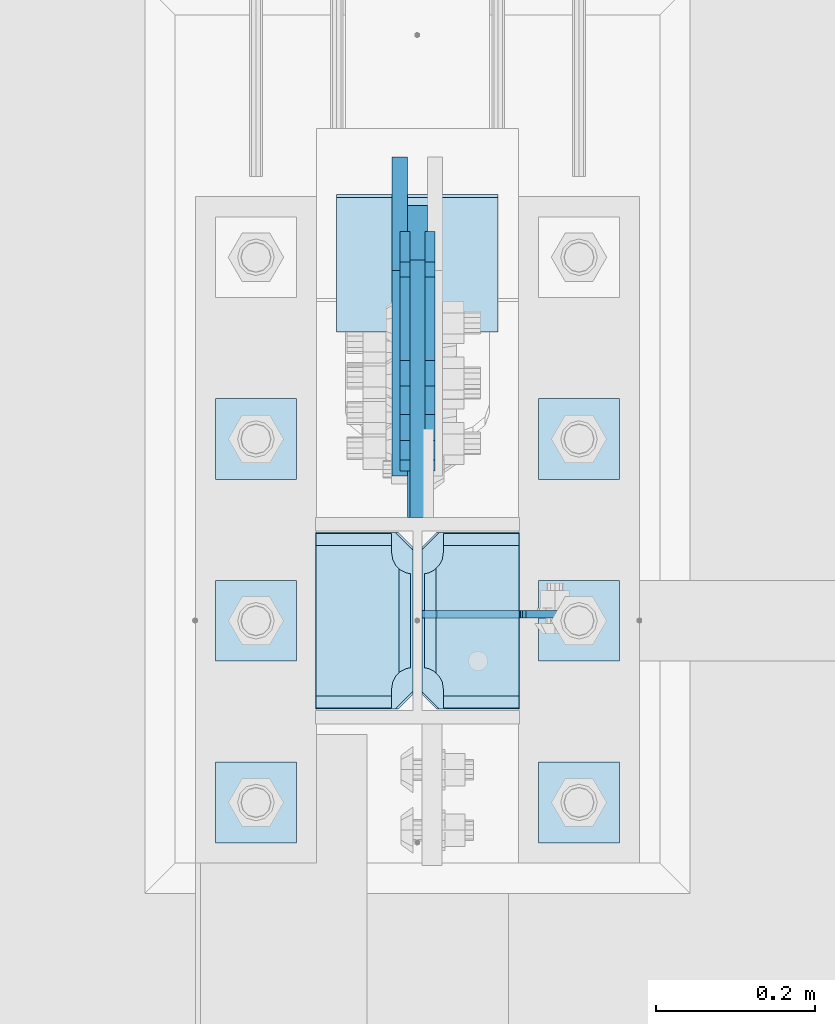
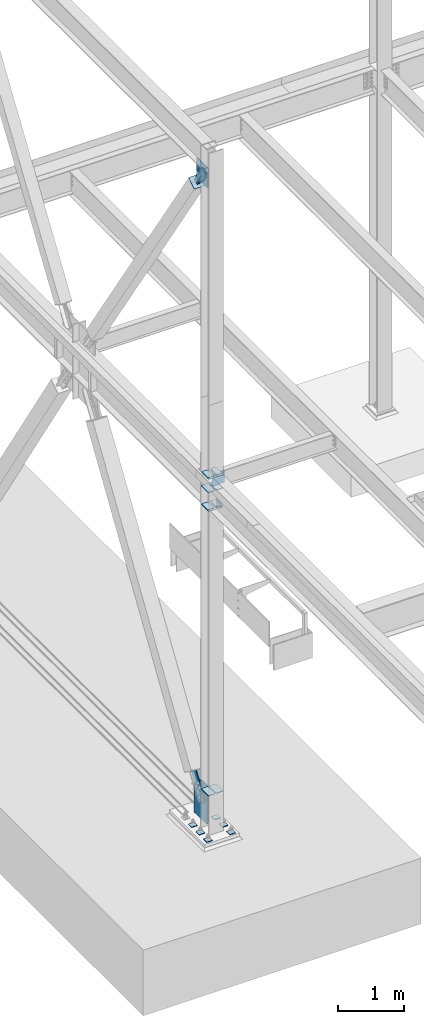
# One storey, part 3330 of 3843: 21 plates, 7 elements without a shape of their own.
"""IFC2X3 building model written with IfcOpenShell, lengths in millimetres."""

from ifc_helpers import new_model, si_unit, frame, origin_with_axes, place, context, subcontext, project, spatial, faceted_brep, material, type_object, element, aggregate, save


model = new_model("IFC2X3")

# Units and contexts
model_context = context("Model", 3, precision=1e-05, world=origin_with_axes())
body_context = subcontext(model_context, "Body", "Model", "MODEL_VIEW")
ifc_project = project(units=[si_unit("LENGTHUNIT", "METRE", prefix="MILLI"), si_unit("AREAUNIT", "SQUARE_METRE"), si_unit("VOLUMEUNIT", "CUBIC_METRE"), si_unit("MASSUNIT", "GRAM", prefix="KILO"), si_unit("TIMEUNIT", "SECOND"), si_unit("PLANEANGLEUNIT", "RADIAN"), si_unit("SOLIDANGLEUNIT", "STERADIAN"), si_unit("THERMODYNAMICTEMPERATUREUNIT", "DEGREE_CELSIUS"), si_unit("LUMINOUSINTENSITYUNIT", "LUMEN")], contexts=[model_context])

# Site, building, storey
site_placement = place(None, origin_with_axes())
site = spatial("IfcSite", under=ifc_project, at=site_placement, CompositionType="ELEMENT")
building_placement = place(site_placement, origin_with_axes())
building = spatial("IfcBuilding", under=site, at=building_placement, Name="Undefined", CompositionType="ELEMENT")
storey_placement = place(building_placement, origin_with_axes())
storey = spatial("IfcBuildingStorey", under=building, at=storey_placement, Name="Undefined", CompositionType="ELEMENT", Elevation=0.0)

# Assembly, plates
assembly_1_placement = place(storey_placement, origin_with_axes())
assembly_1 = element("IfcElementAssembly", 1, at=assembly_1_placement, inside=storey, Name="COLUMN", AssemblyPlace="NOTDEFINED", PredefinedType="RIGID_FRAME")
ifc_material_1 = material(Name="STEEL/A572-50")
plate_type_1 = type_object("IfcPlateType", PredefinedType="NOTDEFINED")
plate_1_placement = place(assembly_1_placement, frame((-128.5875, 96370.775, 30540.5659367631), z_axis=(0.0, 1.0, 0.0), x_axis=(1.0, 0.0, 0.0)))
plate_1 = element("IfcPlate", 2, at=plate_1_placement, type_object=plate_type_1, material=ifc_material_1, Name="STIFFENER", context=body_context, shape_type="Brep", body=[
    faceted_brep([(0.0, -6.3499999046162, 0.0), (0.0, -6.34999999999854, 222.25), (0.0, 6.34999999999854, 222.25), (7.27595761418343e-12, 6.3499999046162, 0.0), (103.981250762939, -6.34999999999854, 222.25), (103.981250762939, 6.34999999999854, 222.25), (123.03125, -6.34999999999854, 203.200000762939), (123.03125, 6.34999999999854, 203.200000762939), (123.03125, -6.34999999999854, 19.0499992370605), (123.03125, 6.34999999999854, 19.0499992370605), (103.981250762939, -6.34999999999854, 0.0), (103.981250762939, 6.34999999999854, 0.0)], [[[0, 1, 2, 3]], [[1, 4, 5, 2]], [[4, 6, 7, 5]], [[6, 8, 9, 7]], [[8, 10, 11, 9]], [[10, 0, 3, 11]], [[5, 7, 9, 11, 3, 2]], [[10, 8, 6, 4, 1, 0]]]),
])
plate_2_placement = place(assembly_1_placement, frame((5.55625, 96370.775, 30540.5659367631), z_axis=(0.0, 1.0, 0.0), x_axis=(1.0, 0.0, 0.0)))
plate_2 = element("IfcPlate", 3, at=plate_2_placement, type_object=plate_type_1, material=ifc_material_1, Name="STIFFENER", context=body_context, shape_type="Brep", body=[
    faceted_brep([(0.0, -6.34999999999854, 19.0499992370605), (0.0, -6.34999999999854, 203.200000762939), (0.0, 6.34999999999854, 203.200000762939), (0.0, 6.34999999999854, 19.0499992370605), (19.0499992370605, -6.34999999999854, 222.25), (19.0499992370605, 6.34999999999854, 222.25), (123.03125, -6.34999999999854, 222.25), (123.03125, 6.34999999999854, 222.25), (123.03125, -6.34999999999854, 0.0), (123.03125, 6.34999999999854, 0.0), (19.0499992370605, -6.34999999999854, 0.0), (19.0499992370605, 6.34999999999854, 0.0)], [[[0, 1, 2, 3]], [[1, 4, 5, 2]], [[4, 6, 7, 5]], [[6, 8, 9, 7]], [[8, 10, 11, 9]], [[10, 0, 3, 11]], [[5, 7, 9, 11, 3, 2]], [[10, 8, 6, 4, 1, 0]]]),
])
plate_type_2 = type_object("IfcPlateType", PredefinedType="NOTDEFINED")
plate_3_placement = place(assembly_1_placement, frame((-5.55625, 96370.775, 36164.8375), z_axis=(0.0, 1.0, 0.0), x_axis=(-1.0, 0.0, 0.0)))
plate_3 = element("IfcPlate", 4, at=plate_3_placement, type_object=plate_type_2, material=ifc_material_1, Name="PLATE", context=body_context, shape_type="Brep", body=[
    faceted_brep([(0.0, -4.76249999999709, 22.2250003814697), (1.77635683940025e-15, -4.76249999999709, 200.02499961853), (1.77635683940025e-15, 4.76249999999709, 200.02499961853), (0.0, 4.76249999999709, 22.2250003814697), (22.2250003814697, -4.76249999999709, 222.25), (22.2250003814697, 4.76249999999709, 222.25), (120.650001525879, -4.76249999999709, 222.25), (120.650001525879, 4.76249999999709, 222.25), (120.650001525879, -4.76249999999709, 0.0), (120.650001525879, 4.76249999999709, 0.0), (22.2250003814697, -4.76249999999709, 0.0), (22.2250003814697, 4.76249999999709, 0.0)], [[[0, 1, 2, 3]], [[1, 4, 5, 2]], [[4, 6, 7, 5]], [[6, 8, 9, 7]], [[8, 10, 11, 9]], [[10, 0, 3, 11]], [[5, 7, 9, 11, 3, 2]], [[10, 8, 6, 4, 1, 0]]]),
])
plate_4_placement = place(assembly_1_placement, frame((126.20625, 96370.775, 36164.8375), z_axis=(0.0, 1.0, 0.0), x_axis=(-1.0, 0.0, 0.0)))
plate_4 = element("IfcPlate", 5, at=plate_4_placement, type_object=plate_type_2, material=ifc_material_1, Name="PLATE", context=body_context, shape_type="Brep", body=[
    faceted_brep([(0.0, -4.76249999999709, 0.0), (7.105427357601e-14, -4.76249999999709, 222.25), (7.105427357601e-14, 4.76249999999709, 222.25), (0.0, 4.76249999999709, 0.0), (98.4249996185303, -4.76249999999709, 222.25), (98.4249996185303, 4.76249999999709, 222.25), (120.65, -4.76249999999709, 200.02499961853), (120.65, 4.76249999999709, 200.02499961853), (120.65, -4.76249999999709, 22.2250003814697), (120.65, 4.76249999999709, 22.2250003814697), (98.4249996185303, -4.76249999999709, 0.0), (98.4249996185303, 4.76249999999709, 0.0)], [[[0, 1, 2, 3]], [[1, 4, 5, 2]], [[4, 6, 7, 5]], [[6, 8, 9, 7]], [[8, 10, 11, 9]], [[10, 0, 3, 11]], [[5, 7, 9, 11, 3, 2]], [[10, 8, 6, 4, 1, 0]]]),
])
plate_type_3 = type_object("IfcPlateType", PredefinedType="NOTDEFINED")
plate_5_placement = place(assembly_1_placement, frame((-5.55625, 96369.1875, 35826.7), z_axis=(0.0, 1.0, 0.0), x_axis=(-1.0, 0.0, 0.0)))
plate_5 = element("IfcPlate", 6, at=plate_5_placement, type_object=plate_type_3, material=ifc_material_1, Name="PLATE", context=body_context, shape_type="Brep", body=[
    faceted_brep([(15.8628540477987, 9.2764413265686, 176.60415524448), (17.8394465694582, 12.6999999999971, 178.580747766144), (17.8394465694582, 12.6999999999971, 46.8442522338592), (15.8628540477985, 9.2764413265686, 48.8208447555226), (8.33959589993262, -3.75422402399272, 52.6541362449789), (3.17474995228986, -12.6999999999971, 53.4721674797547), (3.17474995228986, -12.6999999999971, 171.952832520248), (8.33959589993288, -3.75422402399272, 172.770863755024), (122.237500000003, 12.6999999999971, 17.8391965695046), (122.237500000003, -12.6999999999971, 3.17449995232892), (26.9874992370605, -12.6999999999971, 3.17449995232892), (26.9874992370605, 12.6999999999971, 17.8391965695046), (26.9874992370605, 12.6999999999971, 207.584803430516), (26.9874992370605, -12.6999999999971, 222.249500047692), (122.237500000003, -12.6999999999971, 222.249500047692), (122.237500000003, 12.6999999999971, 207.584803430516), (8.33959589993174, -12.6999999999971, 172.770863755024), (15.8628540477948, -12.6999999999971, 176.60415524448), (21.833345518462, -12.6999999999971, 182.574646715148), (21.833345518462, 12.6999999999971, 182.574646715148), (25.6666370079183, -12.6999999999971, 190.097904863011), (25.6666370079183, 12.6999999999971, 190.097904863011), (26.9874992370605, -12.6999999999971, 198.437500762942), (26.9874992370605, 12.6999999999971, 198.437500762942), (26.9874992370605, -12.6999999999971, 26.9874992370605), (26.9874992370605, 12.6999999999971, 26.9874992370605), (25.6666370079183, -12.6999999999971, 35.3270951369923), (25.6666370079183, 12.6999999999971, 35.3270951369923), (21.833345518462, -12.6999999999971, 42.8503532848626), (21.833345518462, 12.6999999999971, 42.8503532848626), (15.8628540477948, -12.6999999999971, 48.8208447555226), (8.33959589993174, -12.6999999999971, 52.6541362449789)], [[[0, 1, 2, 3, 4, 5, 6, 7]], [[8, 9, 10, 11]], [[12, 13, 14, 15]], [[16, 7, 6]], [[16, 17, 0, 7]], [[17, 18, 19, 1, 0]], [[18, 20, 21, 19]], [[20, 22, 23, 21]], [[23, 22, 13, 12]], [[15, 14, 9, 8]], [[24, 25, 11, 10]], [[24, 26, 27, 25]], [[26, 28, 29, 27]], [[29, 28, 30, 3, 2]], [[30, 31, 4, 3]], [[31, 5, 4]], [[19, 21, 23, 12, 15, 8, 11, 25, 27, 29, 2, 1]], [[31, 30, 28, 26, 24, 10, 9, 14, 13, 22, 20, 18, 17, 16, 6, 5]]]),
])
plate_6_placement = place(assembly_1_placement, frame((-5.55625, 96369.1875, 36423.6), z_axis=(0.0, 1.0, 0.0), x_axis=(-1.0, 0.0, 0.0)))
plate_6 = element("IfcPlate", 7, at=plate_6_placement, type_object=plate_type_3, material=ifc_material_1, Name="PLATE", context=body_context, shape_type="Brep", body=[
    faceted_brep([(15.8628540477987, 9.2764413265686, 176.60415524448), (17.8394465694582, 12.6999999999971, 178.580747766144), (17.8394465694582, 12.6999999999971, 46.8442522338592), (15.8628540477985, 9.2764413265686, 48.8208447555226), (8.33959589993262, -3.75422402399272, 52.6541362449789), (3.17474995228986, -12.6999999999971, 53.4721674797547), (3.17474995228986, -12.6999999999971, 171.952832520248), (8.33959589993288, -3.75422402399272, 172.770863755024), (26.9874992370605, 12.6999999999971, 207.584803430516), (26.9874992370605, -12.6999999999971, 222.249500047692), (122.237500000003, -12.6999999999971, 222.249500047692), (122.237500000003, 12.6999999999971, 207.584803430516), (122.237500000003, 12.6999999999971, 17.8391965695046), (122.237500000003, -12.6999999999971, 3.17449995232892), (26.9874992370605, -12.6999999999971, 3.17449995232892), (26.9874992370605, 12.6999999999971, 17.8391965695046), (8.33959589993174, -12.6999999999971, 172.770863755024), (15.8628540477948, -12.6999999999971, 176.60415524448), (21.833345518462, -12.6999999999971, 182.574646715148), (21.833345518462, 12.6999999999971, 182.574646715148), (25.6666370079183, -12.6999999999971, 190.097904863011), (25.6666370079183, 12.6999999999971, 190.097904863011), (26.9874992370605, -12.6999999999971, 198.437500762942), (26.9874992370605, 12.6999999999971, 198.437500762942), (26.9874992370605, -12.6999999999971, 26.9874992370605), (26.9874992370605, 12.6999999999971, 26.9874992370605), (25.6666370079183, -12.6999999999971, 35.3270951369923), (25.6666370079183, 12.6999999999971, 35.3270951369923), (21.833345518462, -12.6999999999971, 42.8503532848626), (21.833345518462, 12.6999999999971, 42.8503532848626), (15.8628540477948, -12.6999999999971, 48.8208447555226), (8.33959589993174, -12.6999999999971, 52.6541362449789)], [[[0, 1, 2, 3, 4, 5, 6, 7]], [[8, 9, 10, 11]], [[12, 13, 14, 15]], [[16, 7, 6]], [[16, 17, 0, 7]], [[17, 18, 19, 1, 0]], [[18, 20, 21, 19]], [[20, 22, 23, 21]], [[23, 22, 9, 8]], [[11, 10, 13, 12]], [[24, 25, 15, 14]], [[24, 26, 27, 25]], [[26, 28, 29, 27]], [[29, 28, 30, 3, 2]], [[30, 31, 4, 3]], [[31, 5, 4]], [[19, 21, 23, 8, 11, 12, 15, 25, 27, 29, 2, 1]], [[31, 30, 28, 26, 24, 14, 13, 10, 9, 22, 20, 18, 17, 16, 6, 5]]]),
])
plate_7_placement = place(assembly_1_placement, frame((127.79375, 96369.1875, 35826.7), z_axis=(0.0, 1.0, 0.0), x_axis=(-1.0, 0.0, 0.0)))
plate_7 = element("IfcPlate", 8, at=plate_7_placement, type_object=plate_type_3, material=ifc_material_1, Name="PLATE", context=body_context, shape_type="Brep", body=[
    faceted_brep([(106.374645952202, 9.2764413265686, 48.8208447555226), (104.398053430486, 12.6999999999971, 46.8442522338009), (104.398053430486, 12.6999999999971, 178.580747766202), (106.374645952201, 9.2764413265686, 176.60415524448), (113.897904100067, -3.75422402399272, 172.770863755024), (119.062750047655, -12.6999999999971, 171.952832520255), (119.062750047655, -12.6999999999971, 53.4721674797474), (113.897904100067, -3.75422402399272, 52.6541362449789), (0.0, 12.6999999999971, 207.584803430516), (0.0, -12.6999999999971, 222.249500047692), (95.2500007629424, -12.6999999999971, 222.249500047692), (95.2500007629424, 12.6999999999971, 207.584803430516), (95.2500007629424, 12.6999999999971, 17.8391965694973), (95.2500007629424, -12.6999999999971, 3.17449995232164), (0.0, -12.6999999999971, 3.17449995232164), (0.0, 12.6999999999971, 17.8391965694973), (95.2500007629424, -12.6999999999971, 198.437500762942), (95.2500007629424, 12.6999999999971, 198.437500762942), (96.5708629920846, -12.6999999999971, 190.097904863011), (96.5708629920846, 12.6999999999971, 190.097904863011), (100.404154481541, -12.6999999999971, 182.574646715148), (100.404154481541, 12.6999999999971, 182.574646715148), (106.374645952208, -12.6999999999971, 176.60415524448), (113.897904100071, -12.6999999999971, 172.770863755024), (113.897904100071, -12.6999999999971, 52.6541362449789), (106.374645952208, -12.6999999999971, 48.8208447555226), (100.404154481541, -12.6999999999971, 42.8503532848626), (100.404154481541, 12.6999999999971, 42.8503532848626), (96.5708629920846, -12.6999999999971, 35.3270951369923), (96.5708629920846, 12.6999999999971, 35.3270951369923), (95.2500007629424, -12.6999999999971, 26.9874992370605), (95.2500007629424, 12.6999999999971, 26.9874992370605)], [[[0, 1, 2, 3, 4, 5, 6, 7]], [[8, 9, 10, 11]], [[12, 13, 14, 15]], [[15, 14, 9, 8]], [[16, 17, 11, 10]], [[16, 18, 19, 17]], [[18, 20, 21, 19]], [[21, 20, 22, 3, 2]], [[22, 23, 4, 3]], [[23, 5, 4]], [[24, 7, 6]], [[24, 25, 0, 7]], [[25, 26, 27, 1, 0]], [[26, 28, 29, 27]], [[28, 30, 31, 29]], [[31, 30, 13, 12]], [[27, 29, 31, 12, 15, 8, 11, 17, 19, 21, 2, 1]], [[13, 30, 28, 26, 25, 24, 6, 5, 23, 22, 20, 18, 16, 10, 9, 14]]]),
])
plate_8_placement = place(assembly_1_placement, frame((127.79375, 96369.1875, 36423.6), z_axis=(0.0, 1.0, 0.0), x_axis=(-1.0, 0.0, 0.0)))
plate_8 = element("IfcPlate", 9, at=plate_8_placement, type_object=plate_type_3, material=ifc_material_1, Name="PLATE", context=body_context, shape_type="Brep", body=[
    faceted_brep([(106.374645952202, 9.2764413265686, 48.8208447555226), (104.398053430486, 12.6999999999971, 46.8442522338009), (104.398053430486, 12.6999999999971, 178.580747766202), (106.374645952201, 9.2764413265686, 176.60415524448), (113.897904100067, -3.75422402399272, 172.770863755024), (119.062750047655, -12.6999999999971, 171.952832520255), (119.062750047655, -12.6999999999971, 53.4721674797474), (113.897904100067, -3.75422402399272, 52.6541362449789), (0.0, 12.6999999999971, 207.584803430516), (0.0, -12.6999999999971, 222.249500047692), (95.2500007629424, -12.6999999999971, 222.249500047692), (95.2500007629424, 12.6999999999971, 207.584803430516), (95.2500007629424, 12.6999999999971, 17.8391965694973), (95.2500007629424, -12.6999999999971, 3.17449995232164), (0.0, -12.6999999999971, 3.17449995232164), (0.0, 12.6999999999971, 17.8391965694973), (95.2500007629424, -12.6999999999971, 198.437500762942), (95.2500007629424, 12.6999999999971, 198.437500762942), (96.5708629920846, -12.6999999999971, 190.097904863011), (96.5708629920846, 12.6999999999971, 190.097904863011), (100.404154481541, -12.6999999999971, 182.574646715148), (100.404154481541, 12.6999999999971, 182.574646715148), (106.374645952208, -12.6999999999971, 176.60415524448), (113.897904100071, -12.6999999999971, 172.770863755024), (113.897904100071, -12.6999999999971, 52.6541362449789), (106.374645952208, -12.6999999999971, 48.8208447555226), (100.404154481541, -12.6999999999971, 42.8503532848626), (100.404154481541, 12.6999999999971, 42.8503532848626), (96.5708629920846, -12.6999999999971, 35.3270951369923), (96.5708629920846, 12.6999999999971, 35.3270951369923), (95.2500007629424, -12.6999999999971, 26.9874992370605), (95.2500007629424, 12.6999999999971, 26.9874992370605)], [[[0, 1, 2, 3, 4, 5, 6, 7]], [[8, 9, 10, 11]], [[12, 13, 14, 15]], [[15, 14, 9, 8]], [[16, 17, 11, 10]], [[16, 18, 19, 17]], [[18, 20, 21, 19]], [[21, 20, 22, 3, 2]], [[22, 23, 4, 3]], [[23, 5, 4]], [[24, 7, 6]], [[24, 25, 0, 7]], [[25, 26, 27, 1, 0]], [[26, 28, 29, 27]], [[28, 30, 31, 29]], [[31, 30, 13, 12]], [[27, 29, 31, 12, 15, 8, 11, 17, 19, 21, 2, 1]], [[13, 30, 28, 26, 25, 24, 6, 5, 23, 22, 20, 18, 16, 10, 9, 14]]]),
])

# Assembly, plate
assembly_2_placement = place(storey_placement, origin_with_axes())
assembly_2 = element("IfcElementAssembly", 10, at=assembly_2_placement, inside=storey, AssemblyPlace="NOTDEFINED", PredefinedType="RIGID_FRAME")
ifc_material_2 = material(Name="STEEL/A36")
plate_type_4 = type_object("IfcPlateType", PredefinedType="NOTDEFINED")
plate_9_placement = place(assembly_2_placement, frame((-15.875, 96933.0535545789, 41635.915781687), z_axis=(0.0, -0.83424452268884, -0.551394664794346), x_axis=(0.0, 0.551394664794348, -0.834244522688839)))
plate_9 = element("IfcPlate", 11, at=plate_9_placement, type_object=plate_type_4, material=ifc_material_2, context=body_context, shape_type="Brep", body=[
    faceted_brep([(0.0, -6.3499999046162, 0.0), (-101.599999999482, -6.35000000000582, -44.6881937832222), (-101.599999999482, 6.35000000000582, -44.6881937832222), (7.27595761418343e-12, 6.3499999046162, 0.0), (-246.684985846376, -6.35000000000582, -44.6881937832586), (-246.684985846376, 6.35000000000582, -44.6881937832586), (-281.313054100305, -6.35000000000582, -37.8002427490646), (-281.313054100305, 6.35000000000582, -37.8002427490646), (-310.669312866783, -6.35000000000582, -18.18501775197), (-310.669312866783, 6.35000000000582, -18.18501775197), (-330.284537863758, -6.35000000000582, 11.1712410146756), (-330.284537863758, 6.35000000000582, 11.1712410146756), (-337.172488897893, -6.35000000000582, 45.7993031645856), (-337.172488897893, 6.35000000000582, 45.7993031645856), (-330.284537863699, -6.35000000000582, 80.4273714186893), (-330.284537863699, 6.35000000000582, 80.4273714186893), (-310.669312866681, -6.35000000000582, 109.783630185331), (-310.669312866681, 6.35000000000582, 109.783630185331), (-281.313054100174, -6.35000000000582, 129.39885518244), (-281.313054100174, 6.35000000000582, 129.39885518244), (-246.684988898312, -6.35000000000582, 136.286806216667), (-246.684988898312, 6.35000000000582, 136.286806216667), (-101.599999999322, -6.35000000000582, 136.286806216689), (-101.599999999322, 6.35000000000582, 136.286806216689), (2.18278728425503e-10, -6.35000000000582, 91.5986124321353), (2.18278728425503e-10, 6.35000000000582, 91.5986124321353), (69.8499999987471, -6.35000000000582, 91.598612432037), (69.8499999987471, 6.35000000000582, 91.598612432037), (69.8499999985434, -6.35000000000582, -8.73114913702011e-11), (69.8499999985434, 6.35000000000582, -8.73114913702011e-11)], [[[0, 1, 2, 3]], [[1, 4, 5, 2]], [[4, 6, 7, 5]], [[6, 8, 9, 7]], [[8, 10, 11, 9]], [[10, 12, 13, 11]], [[12, 14, 15, 13]], [[14, 16, 17, 15]], [[16, 18, 19, 17]], [[18, 20, 21, 19]], [[20, 22, 23, 21]], [[22, 24, 25, 23]], [[24, 26, 27, 25]], [[26, 28, 29, 27]], [[28, 0, 3, 29]], [[5, 7, 9, 11, 13, 15, 17, 19, 21, 23, 25, 27, 29, 3, 2]], [[28, 26, 24, 22, 20, 18, 16, 14, 12, 10, 8, 6, 4, 1, 0]]]),
])
aggregate(assembly_2, [plate_9])

assembly_3_placement = place(storey_placement, origin_with_axes())
assembly_3 = element("IfcElementAssembly", 12, at=assembly_3_placement, inside=storey, AssemblyPlace="NOTDEFINED", PredefinedType="RIGID_FRAME")
plate_10_placement = place(assembly_3_placement, frame((15.875, 96933.0535545789, 41635.915781687), z_axis=(0.0, -0.83424452268884, -0.551394664794346), x_axis=(0.0, 0.551394664794348, -0.834244522688839)))
plate_10 = element("IfcPlate", 13, at=plate_10_placement, type_object=plate_type_4, material=ifc_material_2, context=body_context, shape_type="Brep", body=[
    faceted_brep([(0.0, -6.3499999046162, 0.0), (-101.599999999482, -6.35000000000582, -44.6881937832222), (-101.599999999482, 6.35000000000582, -44.6881937832222), (7.27595761418343e-12, 6.3499999046162, 0.0), (-246.684985846376, -6.35000000000582, -44.6881937832586), (-246.684985846376, 6.35000000000582, -44.6881937832586), (-281.313054100305, -6.35000000000582, -37.8002427490646), (-281.313054100305, 6.35000000000582, -37.8002427490646), (-310.669312866783, -6.35000000000582, -18.18501775197), (-310.669312866783, 6.35000000000582, -18.18501775197), (-330.284537863758, -6.35000000000582, 11.1712410146756), (-330.284537863758, 6.35000000000582, 11.1712410146756), (-337.172488897893, -6.35000000000582, 45.7993031645856), (-337.172488897893, 6.35000000000582, 45.7993031645856), (-330.284537863699, -6.35000000000582, 80.4273714186893), (-330.284537863699, 6.35000000000582, 80.4273714186893), (-310.669312866681, -6.35000000000582, 109.783630185331), (-310.669312866681, 6.35000000000582, 109.783630185331), (-281.313054100174, -6.35000000000582, 129.39885518244), (-281.313054100174, 6.35000000000582, 129.39885518244), (-246.684988898312, -6.35000000000582, 136.286806216667), (-246.684988898312, 6.35000000000582, 136.286806216667), (-101.599999999322, -6.35000000000582, 136.286806216689), (-101.599999999322, 6.35000000000582, 136.286806216689), (2.18278728425503e-10, -6.35000000000582, 91.5986124321353), (2.18278728425503e-10, 6.35000000000582, 91.5986124321353), (69.8499999987471, -6.35000000000582, 91.598612432037), (69.8499999987471, 6.35000000000582, 91.598612432037), (69.8499999985434, -6.35000000000582, -8.73114913702011e-11), (69.8499999985434, 6.35000000000582, -8.73114913702011e-11)], [[[0, 1, 2, 3]], [[1, 4, 5, 2]], [[4, 6, 7, 5]], [[6, 8, 9, 7]], [[8, 10, 11, 9]], [[10, 12, 13, 11]], [[12, 14, 15, 13]], [[14, 16, 17, 15]], [[16, 18, 19, 17]], [[18, 20, 21, 19]], [[20, 22, 23, 21]], [[22, 24, 25, 23]], [[24, 26, 27, 25]], [[26, 28, 29, 27]], [[28, 0, 3, 29]], [[5, 7, 9, 11, 13, 15, 17, 19, 21, 23, 25, 27, 29, 3, 2]], [[28, 26, 24, 22, 20, 18, 16, 14, 12, 10, 8, 6, 4, 1, 0]]]),
])
aggregate(assembly_3, [plate_10])

assembly_4_placement = place(storey_placement, origin_with_axes())
assembly_4 = element("IfcElementAssembly", 14, at=assembly_4_placement, inside=storey, Name="Plate", AssemblyPlace="NOTDEFINED", PredefinedType="RIGID_FRAME")
plate_type_5 = type_object("IfcPlateType", PredefinedType="NOTDEFINED")
plate_11_placement = place(assembly_4_placement, frame((-101.6, 96846.8507302591, 41499.0173371492), z_axis=(0.0, 0.83424452268884, 0.551394664794346), x_axis=(1.0, 0.0, 0.0)))
plate_11 = element("IfcPlate", 15, at=plate_11_placement, type_object=plate_type_5, material=ifc_material_2, Name="Plate", context=body_context, shape_type="Brep", body=[
    faceted_brep([(0.0, -3.17499999999927, 0.0), (0.0, -3.17500000043947, 203.200000001736), (0.0, 3.1749999995518, 203.200000001743), (0.0, 3.17499999999927, 0.0), (203.200000000012, -3.17500000043947, 203.200000001736), (203.200000000012, 3.1749999995518, 203.200000001743), (203.199996948242, -3.17499999999927, 0.0), (203.199996948242, 3.17499999999927, 0.0)], [[[0, 1, 2, 3]], [[1, 4, 5, 2]], [[4, 6, 7, 5]], [[6, 0, 3, 7]], [[5, 7, 3, 2]], [[6, 4, 1, 0]]]),
])
aggregate(assembly_4, [plate_11])

assembly_5_placement = place(storey_placement, origin_with_axes())
assembly_5 = element("IfcElementAssembly", 16, at=assembly_5_placement, inside=storey, Name="CB", AssemblyPlace="NOTDEFINED", PredefinedType="RIGID_FRAME")
plate_type_6 = type_object("IfcPlateType", PredefinedType="NOTDEFINED")
plate_12_placement = place(assembly_5_placement, frame((0.0, 96935.5025515636, 42002.075), z_axis=(0.0, 0.0, -1.0), x_axis=(0.0, -1.0, 0.0)))
plate_12 = element("IfcPlate", 17, at=plate_12_placement, type_object=plate_type_6, material=ifc_material_1, Name="CB", context=body_context, shape_type="Brep", body=[
    faceted_brep([(0.0, -9.52500000000146, 0.0), (0.0, -9.525, 242.753716677165), (0.0, 9.525, 242.753716677165), (0.0, 9.52500000000146, 0.0), (193.357024246216, -9.525, 370.553215109874), (193.357024246216, 9.525, 370.553215109874), (323.427549285712, -9.525, 370.553215109874), (323.427549285712, 9.525, 370.553215109874), (323.427549285712, -9.525, 0.0), (323.427549285712, 9.525, 0.0)], [[[0, 1, 2, 3]], [[1, 4, 5, 2]], [[4, 6, 7, 5]], [[6, 8, 9, 7]], [[8, 0, 3, 9]], [[5, 7, 9, 3, 2]], [[8, 6, 4, 1, 0]]]),
])
aggregate(assembly_5, [plate_12])

# Assembly, plates
assembly_6_placement = place(storey_placement, origin_with_axes())
assembly_6 = element("IfcElementAssembly", 18, at=assembly_6_placement, inside=storey, Name="TEMPLATE", AssemblyPlace="NOTDEFINED", PredefinedType="RIGID_FRAME")
plate_type_7 = type_object("IfcPlateType", PredefinedType="NOTDEFINED")
plate_13_placement = place(assembly_6_placement, frame((-152.4, 96304.1, 29825.95), z_axis=(-1.0, 0.0, 0.0), x_axis=(0.0, -1.0, 0.0)))
plate_13 = element("IfcPlate", 19, at=plate_13_placement, type_object=plate_type_7, material=ifc_material_1, Name="Washer Plate", context=body_context, shape_type="Brep", body=[
    faceted_brep([(0.0, -6.3499999046162, 0.0), (-1.67347025126219e-10, -6.35000000000582, 101.600000000151), (-1.67347025126219e-10, 6.35000000000582, 101.600000000151), (7.27595761418343e-12, 6.3499999046162, 0.0), (101.599998474121, -6.34999999999854, 101.599998474121), (101.599998474121, 6.34999999999854, 101.599998474121), (101.6, -6.34999999999854, 0.0), (101.6, 6.34999999999854, 0.0)], [[[0, 1, 2, 3]], [[1, 4, 5, 2]], [[4, 6, 7, 5]], [[6, 0, 3, 7]], [[5, 7, 3, 2]], [[6, 4, 1, 0]]]),
])
plate_14_placement = place(assembly_6_placement, frame((254.0, 96304.1, 29825.95), z_axis=(-1.0, 0.0, 0.0), x_axis=(0.0, -1.0, 0.0)))
plate_14 = element("IfcPlate", 20, at=plate_14_placement, type_object=plate_type_7, material=ifc_material_1, Name="Washer Plate", context=body_context, shape_type="Brep", body=[
    faceted_brep([(0.0, -6.3499999046162, 0.0), (-1.67347025126219e-10, -6.35000000000582, 101.600000000151), (-1.67347025126219e-10, 6.35000000000582, 101.600000000151), (7.27595761418343e-12, 6.3499999046162, 0.0), (101.599998474121, -6.34999999999854, 101.599998474121), (101.599998474121, 6.34999999999854, 101.599998474121), (101.6, -6.34999999999854, 0.0), (101.6, 6.34999999999854, 0.0)], [[[0, 1, 2, 3]], [[1, 4, 5, 2]], [[4, 6, 7, 5]], [[6, 0, 3, 7]], [[5, 7, 3, 2]], [[6, 4, 1, 0]]]),
])
plate_15_placement = place(assembly_6_placement, frame((-152.4, 96532.7, 29825.95), z_axis=(-1.0, 0.0, 0.0), x_axis=(0.0, -1.0, 0.0)))
plate_15 = element("IfcPlate", 21, at=plate_15_placement, type_object=plate_type_7, material=ifc_material_1, Name="Washer Plate", context=body_context, shape_type="Brep", body=[
    faceted_brep([(0.0, -6.3499999046162, 0.0), (-1.67347025126219e-10, -6.35000000000582, 101.600000000151), (-1.67347025126219e-10, 6.35000000000582, 101.600000000151), (7.27595761418343e-12, 6.3499999046162, 0.0), (101.599998474121, -6.34999999999854, 101.599998474121), (101.599998474121, 6.34999999999854, 101.599998474121), (101.6, -6.34999999999854, 0.0), (101.6, 6.34999999999854, 0.0)], [[[0, 1, 2, 3]], [[1, 4, 5, 2]], [[4, 6, 7, 5]], [[6, 0, 3, 7]], [[5, 7, 3, 2]], [[6, 4, 1, 0]]]),
])
plate_16_placement = place(assembly_6_placement, frame((254.0, 96532.7, 29825.95), z_axis=(-1.0, 0.0, 0.0), x_axis=(0.0, -1.0, 0.0)))
plate_16 = element("IfcPlate", 22, at=plate_16_placement, type_object=plate_type_7, material=ifc_material_1, Name="Washer Plate", context=body_context, shape_type="Brep", body=[
    faceted_brep([(0.0, -6.3499999046162, 0.0), (-1.67347025126219e-10, -6.35000000000582, 101.600000000151), (-1.67347025126219e-10, 6.35000000000582, 101.600000000151), (7.27595761418343e-12, 6.3499999046162, 0.0), (101.599998474121, -6.34999999999854, 101.599998474121), (101.599998474121, 6.34999999999854, 101.599998474121), (101.6, -6.34999999999854, 0.0), (101.6, 6.34999999999854, 0.0)], [[[0, 1, 2, 3]], [[1, 4, 5, 2]], [[4, 6, 7, 5]], [[6, 0, 3, 7]], [[5, 7, 3, 2]], [[6, 4, 1, 0]]]),
])
plate_17_placement = place(assembly_6_placement, frame((-152.4, 96761.3, 29825.95), z_axis=(-1.0, 0.0, 0.0), x_axis=(0.0, -1.0, 0.0)))
plate_17 = element("IfcPlate", 23, at=plate_17_placement, type_object=plate_type_7, material=ifc_material_1, Name="Washer Plate", context=body_context, shape_type="Brep", body=[
    faceted_brep([(0.0, -6.3499999046162, 0.0), (-1.67347025126219e-10, -6.35000000000582, 101.600000000151), (-1.67347025126219e-10, 6.35000000000582, 101.600000000151), (7.27595761418343e-12, 6.3499999046162, 0.0), (101.599998474121, -6.34999999999854, 101.599998474121), (101.599998474121, 6.34999999999854, 101.599998474121), (101.6, -6.34999999999854, 0.0), (101.6, 6.34999999999854, 0.0)], [[[0, 1, 2, 3]], [[1, 4, 5, 2]], [[4, 6, 7, 5]], [[6, 0, 3, 7]], [[5, 7, 3, 2]], [[6, 4, 1, 0]]]),
])
plate_18_placement = place(assembly_6_placement, frame((254.0, 96761.3, 29825.95), z_axis=(-1.0, 0.0, 0.0), x_axis=(0.0, -1.0, 0.0)))
plate_18 = element("IfcPlate", 24, at=plate_18_placement, type_object=plate_type_7, material=ifc_material_1, Name="Washer Plate", context=body_context, shape_type="Brep", body=[
    faceted_brep([(0.0, -6.3499999046162, 0.0), (-1.67347025126219e-10, -6.35000000000582, 101.600000000151), (-1.67347025126219e-10, 6.35000000000582, 101.600000000151), (7.27595761418343e-12, 6.3499999046162, 0.0), (101.599998474121, -6.34999999999854, 101.599998474121), (101.599998474121, 6.34999999999854, 101.599998474121), (101.6, -6.34999999999854, 0.0), (101.6, 6.34999999999854, 0.0)], [[[0, 1, 2, 3]], [[1, 4, 5, 2]], [[4, 6, 7, 5]], [[6, 0, 3, 7]], [[5, 7, 3, 2]], [[6, 4, 1, 0]]]),
])
aggregate(assembly_6, [plate_13, plate_14, plate_15, plate_16, plate_17, plate_18])

# Assembly, plate
assembly_7_placement = place(storey_placement, origin_with_axes())
assembly_7 = element("IfcElementAssembly", 25, at=assembly_7_placement, inside=storey, AssemblyPlace="NOTDEFINED", PredefinedType="RIGID_FRAME")
plate_type_8 = type_object("IfcPlateType", PredefinedType="NOTDEFINED")
plate_19_placement = place(assembly_7_placement, frame((-22.225, 97027.4041665625, 30514.6134314622), z_axis=(0.0, -0.84208653813787, 0.539342435088301), x_axis=(0.0, 0.539342435088305, 0.842086538137867)))
plate_19 = element("IfcPlate", 26, at=plate_19_placement, type_object=plate_type_8, material=ifc_material_2, context=body_context, shape_type="Brep", body=[
    faceted_brep([(0.0, -9.52500000000146, 0.0), (-101.599999999351, -9.52499999999418, -12.3260213857429), (-101.599999999351, 9.52499999999418, -12.3260213857429), (0.0, 9.52500000000146, 0.0), (-364.729297663791, -9.52499999999418, -12.3260213864851), (-364.729297663791, 9.52499999999418, -12.3260213864851), (-401.787405129209, -9.52499999999418, -4.95470550008758), (-401.787405129209, 9.52499999999418, -4.95470550008758), (-433.203751665707, -9.52499999999418, 16.0370261367789), (-433.203751665707, 9.52499999999418, 16.0370261367789), (-454.195483303061, -9.52499999999418, 47.4533726729569), (-454.195483303061, 9.52499999999418, 47.4533726729569), (-461.566799190045, -9.52499999999418, 84.5114770857908), (-461.566799190045, 9.52499999999418, 84.5114770857908), (-454.195483303822, -9.52499999999418, 121.569584551733), (-454.195483303822, 9.52499999999418, 121.569584551733), (-433.203751666773, -9.52499999999418, 152.985931088682), (-433.203751666773, 9.52499999999418, 152.985931088682), (-401.787405130151, -9.52499999999418, 173.977662726218), (-401.787405130151, 9.52499999999418, 173.977662726218), (-364.729299191746, -9.52499999999418, 181.348978613009), (-364.729299191746, 9.52499999999418, 181.348978613009), (-101.600000001839, -9.52499999999418, 181.348978613736), (-101.600000001839, 9.52499999999418, 181.348978613736), (-2.16823536902666e-09, -9.52499999999418, 169.022957228546), (-2.16823536902666e-09, 9.52499999999418, 169.022957228546), (69.8499999974956, -9.52499999999418, 169.02295722875), (69.8499999974956, 9.52499999999418, 169.02295722875), (69.8499999979995, -9.52499999999418, -4.00177668780088e-10), (69.8499999979995, 9.52499999999418, -4.00177668780088e-10)], [[[0, 1, 2, 3]], [[1, 4, 5, 2]], [[4, 6, 7, 5]], [[6, 8, 9, 7]], [[8, 10, 11, 9]], [[10, 12, 13, 11]], [[12, 14, 15, 13]], [[14, 16, 17, 15]], [[16, 18, 19, 17]], [[18, 20, 21, 19]], [[20, 22, 23, 21]], [[22, 24, 25, 23]], [[24, 26, 27, 25]], [[26, 28, 29, 27]], [[28, 0, 3, 29]], [[5, 7, 9, 11, 13, 15, 17, 19, 21, 23, 25, 27, 29, 3, 2]], [[28, 26, 24, 22, 20, 18, 16, 14, 12, 10, 8, 6, 4, 1, 0]]]),
])
aggregate(assembly_7, [plate_19])

# Plate
plate_type_9 = type_object("IfcPlateType", PredefinedType="NOTDEFINED")
plate_20_placement = place(assembly_1_placement, frame((0.0, 96612.075, 29819.6), z_axis=(0.0, 0.0, 1.0), x_axis=(0.0, 1.0, 0.0)))
plate_20 = element("IfcPlate", 27, at=plate_20_placement, type_object=plate_type_9, material=ifc_material_1, Name="CB", context=body_context, shape_type="Brep", body=[
    faceted_brep([(0.0, -12.6999999999971, 19.0499992370605), (0.0, -12.7, 720.965936763103), (0.0, 12.7, 720.965936763103), (0.0, 12.6999999999971, 19.0499992370605), (186.431443488676, -12.7, 720.965936763103), (186.431443488676, 12.7, 720.965936763103), (392.300549899941, -12.7, 589.110194944889), (392.300549899941, 12.7, 589.110194944889), (392.300549899941, -12.7, 0.0), (392.300549899941, 12.7, 0.0), (19.0500015258731, -12.6999999999971, -6.33008312433958e-10), (19.0500015258731, 12.6999999999971, 0.0)], [[[0, 1, 2, 3]], [[1, 4, 5, 2]], [[4, 6, 7, 5]], [[6, 8, 9, 7]], [[8, 10, 11, 9]], [[10, 0, 3, 11]], [[5, 7, 9, 11, 3, 2]], [[10, 8, 6, 4, 1, 0]]]),
])

plate_type_10 = type_object("IfcPlateType", PredefinedType="NOTDEFINED")
plate_21_placement = place(assembly_1_placement, frame((5.55624999999998, 96489.8379999161, 36188.65), z_axis=(0.707106781186548, 0.0, 0.707106781186548), x_axis=(0.707106781186548, 0.0, -0.707106781186548)))
plate_21 = element("IfcPlate", 28, at=plate_21_placement, type_object=plate_type_10, material=ifc_material_1, Name="PLATE", context=body_context, shape_type="Brep", body=[
    faceted_brep([(0.0, -4.76249999999709, 0.0), (-143.684097936422, -4.76250000000073, 143.684097936413), (-143.684097936422, 4.76250000000073, 143.684097936413), (0.0, 4.76249999999709, 0.0), (-143.684097936422, -4.76250000000073, 170.624866299499), (-143.684097936422, 4.76250000000073, 170.624866299499), (-70.1582508102547, -4.76249999999709, 244.150713155974), (-70.1582508102547, 4.76249999999709, 244.150713155974), (-66.0380743421119, -4.76249999999709, 241.397699255504), (-66.0380743421119, 4.76249999999709, 241.397699255504), (-61.1779948240692, -4.76249999999709, 240.43096933292), (-61.1779948240692, 4.76249999999709, 240.43096933292), (-56.3179153060337, -4.76249999999709, 241.397699255518), (-56.3179153060337, 4.76249999999709, 241.397699255518), (-52.1977388378837, -4.76249999999709, 244.150713155996), (-52.1977388378837, 4.76249999999709, 244.150713155996), (1.68379802339769, -4.76249999999709, 298.032250017288), (1.68379802339769, 4.76249999999709, 298.032250017288), (163.328411627398, -4.76250000000073, 136.387642905036), (163.328411627398, 4.76250000000073, 136.387642905036), (26.9407683631998, -4.76249999999709, 1.30967237055302e-10), (26.9407683631998, 4.76249999999709, 1.30967237055302e-10)], [[[0, 1, 2, 3]], [[1, 4, 5, 2]], [[4, 6, 7, 5]], [[6, 8, 9, 7]], [[8, 10, 11, 9]], [[10, 12, 13, 11]], [[12, 14, 15, 13]], [[14, 16, 17, 15]], [[16, 18, 19, 17]], [[18, 20, 21, 19]], [[20, 0, 3, 21]], [[5, 7, 9, 11, 13, 15, 17, 19, 21, 3, 2]], [[20, 18, 16, 14, 12, 10, 8, 6, 4, 1, 0]]]),
])

aggregate(assembly_1, [plate_1, plate_2, plate_3, plate_4, plate_20, plate_5, plate_6, plate_7, plate_8, plate_21])

save(model, "model.ifc")
